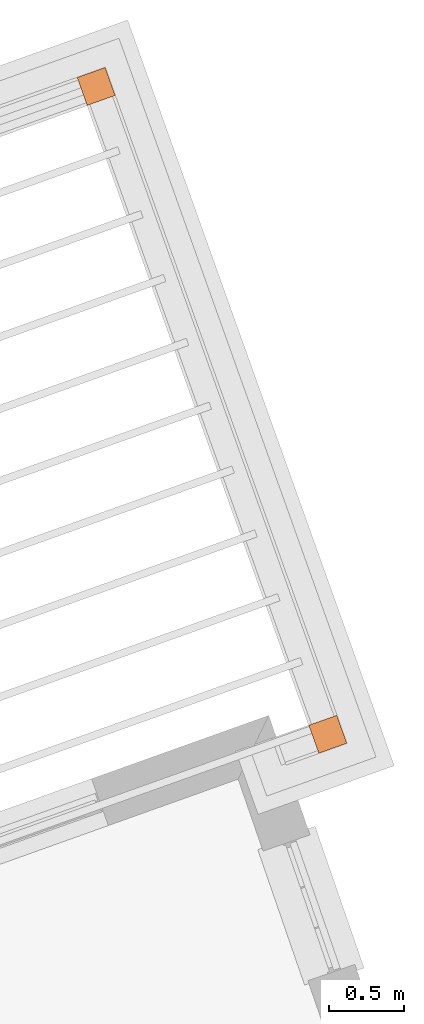
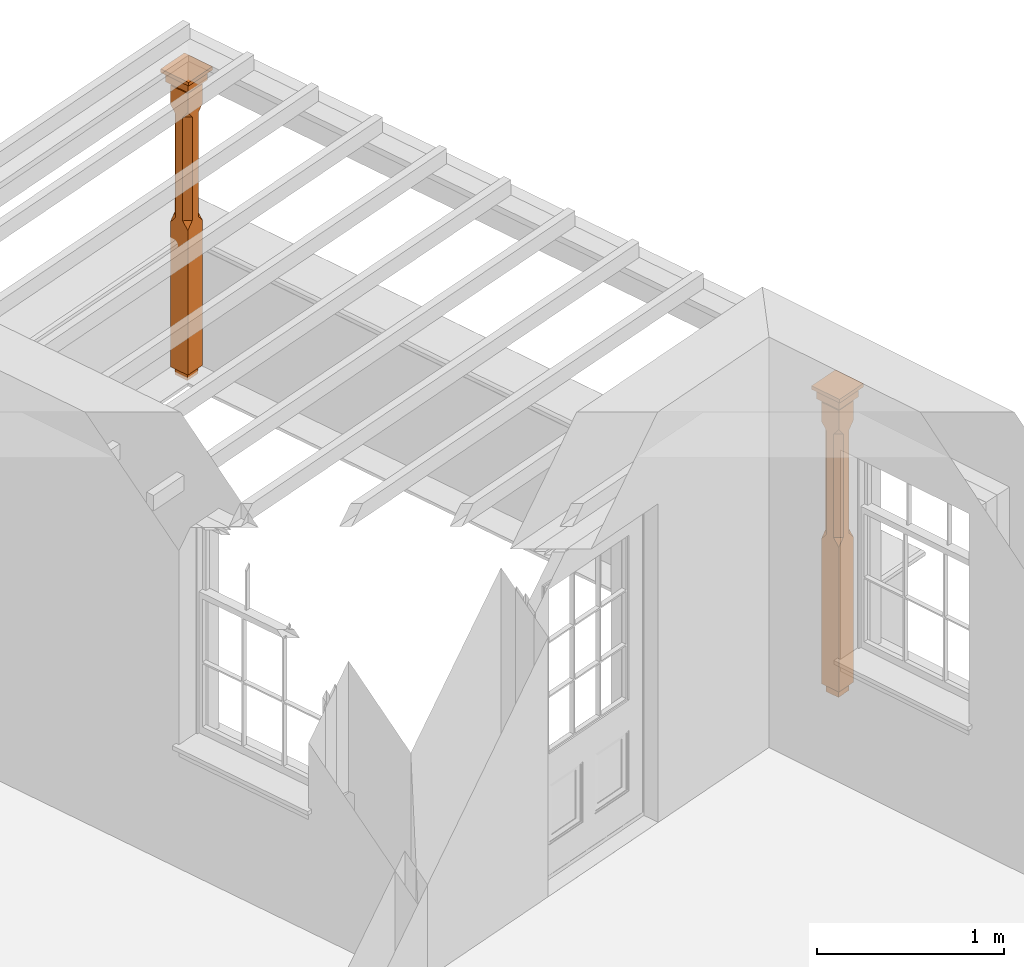
# One storey, part 12 of 12: 2 proxies.
"""IFC2X3 building model written with IfcOpenShell, lengths in metres."""

from ifc_helpers import new_model, si_unit, frame, origin, place, context, subcontext, project, spatial, faceted_brep, element, save


model = new_model("IFC2X3")

# Units and contexts
model_context = context("Model", 3, world=origin())
body_context = subcontext(model_context, "Body", "Model", "MODEL_VIEW")
ifc_project = project(units=[si_unit("PLANEANGLEUNIT", "RADIAN"), si_unit("MASSUNIT", "GRAM", prefix="KILO"), si_unit("FORCEUNIT", "NEWTON", prefix="KILO"), si_unit("LENGTHUNIT", "METRE")], contexts=[model_context])

# Site, building, storey
site_placement = place(None, origin())
site = spatial("IfcSite", under=ifc_project, at=site_placement, CompositionType="ELEMENT")
building_placement = place(None, origin())
building = spatial("IfcBuilding", under=site, at=building_placement, Name="Building plot-12", CompositionType="ELEMENT")
storey_placement = place(None, frame((0.0, 0.0, 6.45)))
storey = spatial("IfcBuildingStorey", under=building, at=storey_placement, Name="Floor 1", CompositionType="ELEMENT", Elevation=6.45)

# Proxies
proxy_1_placement = place(storey_placement, frame((61.2173610753454, 41.0996158852157, 0.0), z_axis=(0.0, 0.0, 1.0), x_axis=(-0.336694271831302, 0.941614022472048, 0.0)))
element("IfcBuildingElementProxy", 1, at=proxy_1_placement, inside=storey, Name="pergola post", CompositionType="ELEMENT", context=body_context, shape_type="Brep", held_by="IfcProductRepresentation", body=[
    faceted_brep([(0.0246, -0.0615, 1.72), (0.0615, -0.0246, 1.72), (0.0615, -0.0615, 1.766667), (0.0615, -0.0246, 1.044444), (0.0246, -0.0615, 1.044444), (0.0615, 0.0246, 1.72), (0.0615, 0.0615, 1.766667), (-0.0246, -0.0615, 1.72), (-0.0615, -0.0615, 1.766667), (-0.0246, -0.0615, 1.044444), (0.0615, -0.0615, 0.997778), (0.0615, 0.0246, 1.044444), (0.0246, 0.0615, 1.72), (0.0615, 0.0615, 1.891111), (0.0615, -0.0615, 1.891111), (-0.0615, -0.0615, 1.891111), (-0.0615, -0.0246, 1.72), (-0.0615, -0.0246, 1.044444), (-0.0615, -0.0615, 0.997778), (0.0615, 0.0615, 0.997778), (0.0246, 0.0615, 1.044444), (-0.0246, 0.0615, 1.72), (-0.0615, 0.0615, 1.766667), (0.04305, 0.04305, 1.891111), (0.04305, -0.04305, 1.891111), (-0.0615, 0.0615, 1.891111), (-0.04305, -0.04305, 1.891111), (-0.0615, 0.0246, 1.72), (-0.0615, 0.0246, 1.044444), (0.0615, -0.0615, 0.053333), (-0.0615, -0.0615, 0.053333), (0.0615, 0.0615, 0.053333), (-0.0246, 0.0615, 1.044444), (-0.04305, 0.04305, 1.891111), (0.04305, 0.04305, 1.914444), (0.04305, -0.04305, 1.914444), (-0.04305, -0.04305, 1.914444), (-0.0615, 0.0615, 0.997778), (-0.0615, 0.0615, 0.053333), (-0.04305, -0.04305, 0.053333), (0.04305, -0.04305, 0.053333), (0.04305, 0.04305, 0.053333), (-0.04305, 0.04305, 1.914444), (0.07995, 0.07995, 1.914444), (0.07995, -0.07995, 1.914444), (-0.07995, -0.07995, 1.914444), (-0.04305, 0.04305, 0.053333), (-0.04305, -0.04305, 0.0), (0.04305, -0.04305, 0.0), (0.04305, 0.04305, 0.0), (-0.07995, 0.07995, 1.914444), (0.07995, 0.07995, 1.976667), (0.07995, -0.07995, 1.976667), (-0.07995, -0.07995, 1.976667), (-0.04305, 0.04305, 0.0), (-0.07995, 0.07995, 1.976667), (0.0984, 0.0984, 1.976667), (0.0984, -0.0984, 1.976667), (-0.0984, -0.0984, 1.976667), (-0.0984, 0.0984, 1.976667), (0.0984, 0.0984, 2.0), (0.0984, -0.0984, 2.0), (-0.0984, -0.0984, 2.0), (-0.0984, 0.0984, 2.0)], [[[0, 1, 2]], [[3, 1, 0, 4]], [[1, 5, 6, 2]], [[7, 0, 2, 8]], [[4, 0, 7, 9]], [[3, 4, 10]], [[1, 3, 11, 5]], [[5, 12, 6]], [[13, 14, 2, 6]], [[15, 8, 2, 14]], [[8, 16, 7]], [[9, 7, 16, 17]], [[9, 18, 10, 4]], [[3, 10, 19, 11]], [[20, 12, 5, 11]], [[21, 22, 6, 12]], [[14, 13, 23, 24]], [[13, 6, 22, 25]], [[25, 22, 8, 15]], [[26, 15, 14, 24]], [[16, 8, 22, 27]], [[27, 28, 17, 16]], [[17, 18, 9]], [[29, 10, 18, 30]], [[31, 19, 10, 29]], [[20, 11, 19]], [[12, 20, 32, 21]], [[21, 27, 22]], [[33, 23, 13, 25]], [[23, 34, 35, 24]], [[26, 33, 25, 15]], [[36, 26, 24, 35]], [[28, 27, 21, 32]], [[17, 28, 37, 18]], [[38, 30, 18, 37]], [[29, 30, 39, 40]], [[31, 38, 37, 19]], [[40, 41, 31, 29]], [[32, 20, 19, 37]], [[33, 42, 34, 23]], [[43, 44, 35, 34]], [[42, 33, 26, 36]], [[36, 35, 44, 45]], [[28, 32, 37]], [[46, 39, 30, 38]], [[39, 47, 48, 40]], [[46, 38, 31, 41]], [[49, 41, 40, 48]], [[43, 34, 42, 50]], [[43, 51, 52, 44]], [[45, 50, 42, 36]], [[53, 45, 44, 52]], [[46, 54, 47, 39]], [[54, 46, 41, 49]], [[50, 55, 51, 43]], [[56, 57, 52, 51]], [[55, 50, 45, 53]], [[53, 52, 57, 58]], [[56, 51, 55, 59]], [[56, 60, 61, 57]], [[58, 59, 55, 53]], [[62, 58, 57, 61]], [[59, 63, 60, 56]], [[63, 62, 61, 60]], [[58, 62, 63, 59]], [[47, 54, 49, 48]]]),
])
proxy_2_placement = place(storey_placement, frame((59.6801169280114, 45.3987405398164, 0.0), z_axis=(0.0, 0.0, 1.0), x_axis=(-0.941614022472053, -0.336694271831285, 0.0)))
element("IfcBuildingElementProxy", 2, at=proxy_2_placement, inside=storey, Name="pergola post", CompositionType="ELEMENT", context=body_context, shape_type="Brep", held_by="IfcProductRepresentation", body=[
    faceted_brep([(0.0246, -0.0615, 1.72), (0.0615, -0.0246, 1.72), (0.0615, -0.0615, 1.766667), (0.0615, -0.0246, 1.044444), (0.0246, -0.0615, 1.044444), (0.0615, 0.0246, 1.72), (0.0615, 0.0615, 1.766667), (-0.0246, -0.0615, 1.72), (-0.0615, -0.0615, 1.766667), (-0.0246, -0.0615, 1.044444), (0.0615, -0.0615, 0.997778), (0.0615, 0.0246, 1.044444), (0.0246, 0.0615, 1.72), (0.0615, 0.0615, 1.891111), (0.0615, -0.0615, 1.891111), (-0.0615, -0.0615, 1.891111), (-0.0615, -0.0246, 1.72), (-0.0615, -0.0246, 1.044444), (-0.0615, -0.0615, 0.997778), (0.0615, 0.0615, 0.997778), (0.0246, 0.0615, 1.044444), (-0.0246, 0.0615, 1.72), (-0.0615, 0.0615, 1.766667), (0.04305, 0.04305, 1.891111), (0.04305, -0.04305, 1.891111), (-0.0615, 0.0615, 1.891111), (-0.04305, -0.04305, 1.891111), (-0.0615, 0.0246, 1.72), (-0.0615, 0.0246, 1.044444), (0.0615, -0.0615, 0.053333), (-0.0615, -0.0615, 0.053333), (0.0615, 0.0615, 0.053333), (-0.0246, 0.0615, 1.044444), (-0.04305, 0.04305, 1.891111), (0.04305, 0.04305, 1.914444), (0.04305, -0.04305, 1.914444), (-0.04305, -0.04305, 1.914444), (-0.0615, 0.0615, 0.997778), (-0.0615, 0.0615, 0.053333), (-0.04305, -0.04305, 0.053333), (0.04305, -0.04305, 0.053333), (0.04305, 0.04305, 0.053333), (-0.04305, 0.04305, 1.914444), (0.07995, 0.07995, 1.914444), (0.07995, -0.07995, 1.914444), (-0.07995, -0.07995, 1.914444), (-0.04305, 0.04305, 0.053333), (-0.04305, -0.04305, 0.0), (0.04305, -0.04305, 0.0), (0.04305, 0.04305, 0.0), (-0.07995, 0.07995, 1.914444), (0.07995, 0.07995, 1.976667), (0.07995, -0.07995, 1.976667), (-0.07995, -0.07995, 1.976667), (-0.04305, 0.04305, 0.0), (-0.07995, 0.07995, 1.976667), (0.0984, 0.0984, 1.976667), (0.0984, -0.0984, 1.976667), (-0.0984, -0.0984, 1.976667), (-0.0984, 0.0984, 1.976667), (0.0984, 0.0984, 2.0), (0.0984, -0.0984, 2.0), (-0.0984, -0.0984, 2.0), (-0.0984, 0.0984, 2.0)], [[[0, 1, 2]], [[3, 1, 0, 4]], [[1, 5, 6, 2]], [[7, 0, 2, 8]], [[4, 0, 7, 9]], [[3, 4, 10]], [[1, 3, 11, 5]], [[5, 12, 6]], [[13, 14, 2, 6]], [[15, 8, 2, 14]], [[8, 16, 7]], [[9, 7, 16, 17]], [[9, 18, 10, 4]], [[3, 10, 19, 11]], [[20, 12, 5, 11]], [[21, 22, 6, 12]], [[14, 13, 23, 24]], [[13, 6, 22, 25]], [[25, 22, 8, 15]], [[26, 15, 14, 24]], [[16, 8, 22, 27]], [[27, 28, 17, 16]], [[17, 18, 9]], [[29, 10, 18, 30]], [[31, 19, 10, 29]], [[20, 11, 19]], [[12, 20, 32, 21]], [[21, 27, 22]], [[33, 23, 13, 25]], [[23, 34, 35, 24]], [[26, 33, 25, 15]], [[36, 26, 24, 35]], [[28, 27, 21, 32]], [[17, 28, 37, 18]], [[38, 30, 18, 37]], [[29, 30, 39, 40]], [[31, 38, 37, 19]], [[40, 41, 31, 29]], [[32, 20, 19, 37]], [[33, 42, 34, 23]], [[43, 44, 35, 34]], [[42, 33, 26, 36]], [[36, 35, 44, 45]], [[28, 32, 37]], [[46, 39, 30, 38]], [[39, 47, 48, 40]], [[46, 38, 31, 41]], [[49, 41, 40, 48]], [[43, 34, 42, 50]], [[43, 51, 52, 44]], [[45, 50, 42, 36]], [[53, 45, 44, 52]], [[46, 54, 47, 39]], [[54, 46, 41, 49]], [[50, 55, 51, 43]], [[56, 57, 52, 51]], [[55, 50, 45, 53]], [[53, 52, 57, 58]], [[56, 51, 55, 59]], [[56, 60, 61, 57]], [[58, 59, 55, 53]], [[62, 58, 57, 61]], [[59, 63, 60, 56]], [[63, 62, 61, 60]], [[58, 62, 63, 59]], [[47, 54, 49, 48]]]),
])

save(model, "model.ifc")
